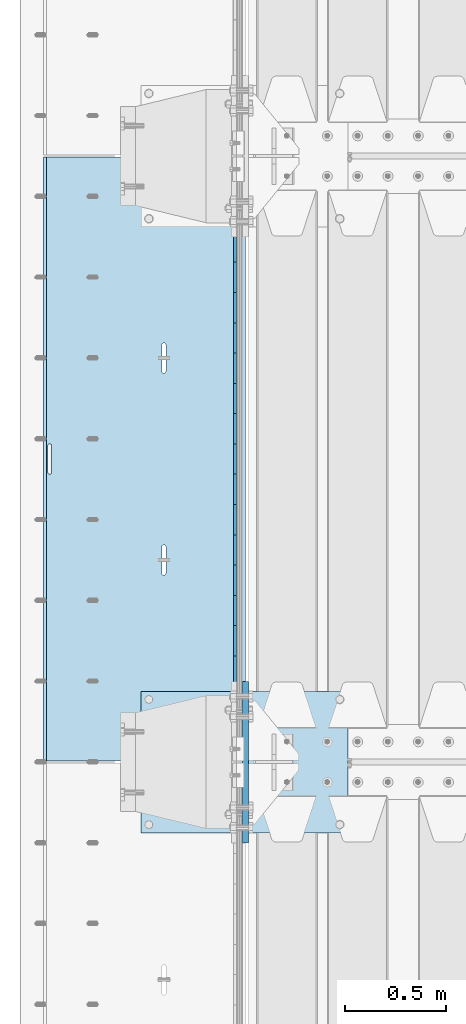
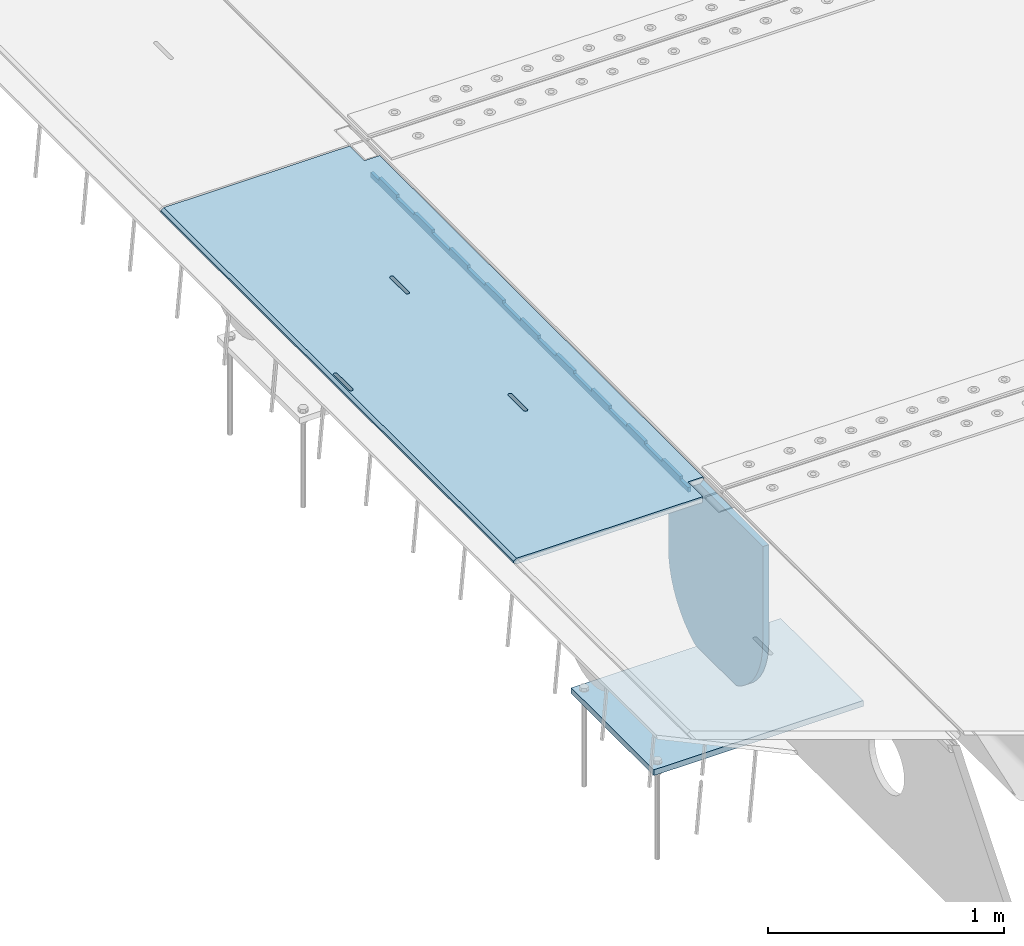
# One storey, part 196 of 257: 4 plates.
"""IFC2X3 building model written with IfcOpenShell, lengths in millimetres."""

from ifc_helpers import new_model, si_unit, frame, origin_with_axes, place, context, subcontext, project, spatial, faceted_brep, material, type_object, element, save


model = new_model("IFC2X3")

# Units and contexts
model_context = context("Model", 3, precision=1e-05, world=origin_with_axes())
body_context = subcontext(model_context, "Body", "Model", "MODEL_VIEW")
ifc_project = project(units=[si_unit("LENGTHUNIT", "METRE", prefix="MILLI"), si_unit("AREAUNIT", "SQUARE_METRE"), si_unit("VOLUMEUNIT", "CUBIC_METRE"), si_unit("MASSUNIT", "GRAM", prefix="KILO"), si_unit("TIMEUNIT", "SECOND"), si_unit("PLANEANGLEUNIT", "RADIAN"), si_unit("SOLIDANGLEUNIT", "STERADIAN"), si_unit("THERMODYNAMICTEMPERATUREUNIT", "DEGREE_CELSIUS"), si_unit("LUMINOUSINTENSITYUNIT", "LUMEN")], contexts=[model_context])

# Site, building, storey
site_placement = place(None, origin_with_axes())
site = spatial("IfcSite", under=ifc_project, at=site_placement, CompositionType="ELEMENT")
building_placement = place(site_placement, origin_with_axes())
building = spatial("IfcBuilding", under=site, at=building_placement, Name="Standard", CompositionType="ELEMENT")
storey_placement = place(building_placement, origin_with_axes())
storey = spatial("IfcBuildingStorey", under=building, at=storey_placement, Name="Undefined", CompositionType="ELEMENT", Elevation=0.0)

# Plates
ifc_material = material(Name="STEEL/S355N")
plate_type_1 = type_object("IfcPlateType", PredefinedType="NOTDEFINED")
plate_1_placement = place(storey_placement, frame((42392.5, 5845.00009945642, -36.018454190458), z_axis=(0.0, -0.999999999987744, -4.95099999993769e-06), x_axis=(0.0, 4.9510000093107e-06, -0.999999999987744)))
element("IfcPlate", 1, at=plate_1_placement, inside=storey, type_object=plate_type_1, material=ifc_material, context=body_context, shape_type="Brep", body=[
    faceted_brep([(7.105427357601e-15, -7.5, 0.0), (-1.24849464100407e-10, -7.5, 70.0), (-1.24849464100407e-10, 7.5, 70.0), (7.105427357601e-15, 7.5, 0.0), (-14.9899997711175, -7.5, 70.0), (-14.9899997711175, 7.5, 70.0), (-14.9899997711161, -7.5, 220.0), (-14.9899997711161, 7.5, 220.0), (-3.90826926377486e-10, -7.5, 220.0), (-3.90826926377486e-10, 7.5, 220.0), (-6.56825704936637e-10, -7.5, 370.0), (-6.56825704936637e-10, 7.5, 370.0), (-14.9899997711147, -7.5, 370.0), (-14.9899997711147, 7.5, 370.0), (-14.9899997711133, -7.5, 520.0), (-14.9899997711133, 7.5, 520.0), (-9.24622156617261e-10, -7.5, 520.0), (-9.24622156617261e-10, 7.5, 520.0), (-1.1906067243217e-09, -7.5, 669.999999999999), (-1.1906067243217e-09, 7.5, 669.999999999999), (-14.9899997711119, -7.5, 669.999999999999), (-14.9899997711119, 7.5, 669.999999999999), (-14.9899997711105, -7.5, 820.0), (-14.9899997711105, 7.5, 820.0), (-1.45477230262259e-09, -7.5, 820.0), (-1.45477230262259e-09, 7.5, 820.0), (-1.72258296515793e-09, -7.5, 970.0), (-1.72258296515793e-09, 7.5, 970.0), (-14.9899997711091, -7.5, 970.000000000001), (-14.9899997711091, 7.5, 970.000000000001), (-14.9899997711077, -7.5, 1120.0), (-14.9899997711077, 7.5, 1120.0), (-1.988560427435e-09, -7.5, 1120.0), (-1.988560427435e-09, 7.5, 1120.0), (-2.2545521005668e-09, -7.5, 1270.0), (-2.2545521005668e-09, 7.5, 1270.0), (-14.9899997711063, -7.5, 1270.0), (-14.9899997711063, 7.5, 1270.0), (-14.9899997711048, -7.5, 1420.0), (-14.9899997711048, 7.5, 1420.0), (-2.52235565767478e-09, -7.5, 1420.0), (-2.52235565767478e-09, 7.5, 1420.0), (-2.78834733080657e-09, -7.5, 1570.0), (-2.78834733080657e-09, 7.5, 1570.0), (-14.9899997711034, -7.5, 1570.0), (-14.9899997711034, 7.5, 1570.0), (-14.989999771102, -7.5, 1720.0), (-14.989999771102, 7.5, 1720.0), (-3.05432479308365e-09, -7.5, 1720.0), (-3.05432479308365e-09, 7.5, 1720.0), (-3.32212835019163e-09, -7.5, 1870.0), (-3.32212835019163e-09, 7.5, 1870.0), (-14.9899997711006, -7.5, 1870.0), (-14.9899997711006, 7.5, 1870.0), (-14.9899997710992, -7.5, 2020.0), (-14.9899997710992, 7.5, 2020.0), (-3.58812002332343e-09, -7.5, 2020.0), (-3.58812002332343e-09, 7.5, 2020.0), (-3.85410459102786e-09, -7.5, 2170.0), (-3.85410459102786e-09, 7.5, 2170.0), (-14.9899997710978, -7.5, 2170.0), (-14.9899997710978, 7.5, 2170.0), (-14.9899997710964, -7.5, 2320.0), (-14.9899997710964, 7.5, 2320.0), (-4.12190104270849e-09, -7.5, 2320.0), (-4.12190104270849e-09, 7.5, 2320.0), (-4.38789982126764e-09, -7.5, 2470.0), (-4.38789982126764e-09, 7.5, 2470.0), (-14.9999999999768, -7.5, 2470.0), (-14.9999999999768, 7.5, 2470.0), (-14.9899997710936, -7.5, 2620.0), (-14.9899997710936, 7.5, 2620.0), (-4.65387728354472e-09, -7.5, 2620.0), (-4.65387728354472e-09, 7.5, 2620.0), (-4.77872674764512e-09, -7.5, 2690.0), (-4.77872674764512e-09, 7.5, 2690.0), (25.0100002289071, -7.5, 2690.0), (25.0100002289071, 7.5, 2690.0), (25.0, -7.5, 0.0), (25.0, 7.5, 0.0)], [[[0, 1, 2, 3]], [[1, 4, 5, 2]], [[4, 6, 7, 5]], [[6, 8, 9, 7]], [[8, 10, 11, 9]], [[10, 12, 13, 11]], [[12, 14, 15, 13]], [[14, 16, 17, 15]], [[16, 18, 19, 17]], [[18, 20, 21, 19]], [[20, 22, 23, 21]], [[22, 24, 25, 23]], [[24, 26, 27, 25]], [[26, 28, 29, 27]], [[28, 30, 31, 29]], [[30, 32, 33, 31]], [[32, 34, 35, 33]], [[34, 36, 37, 35]], [[36, 38, 39, 37]], [[38, 40, 41, 39]], [[40, 42, 43, 41]], [[42, 44, 45, 43]], [[44, 46, 47, 45]], [[46, 48, 49, 47]], [[48, 50, 51, 49]], [[50, 52, 53, 51]], [[52, 54, 55, 53]], [[54, 56, 57, 55]], [[56, 58, 59, 57]], [[58, 60, 61, 59]], [[60, 62, 63, 61]], [[62, 64, 65, 63]], [[64, 66, 67, 65]], [[66, 68, 69, 67]], [[68, 70, 71, 69]], [[70, 72, 73, 71]], [[72, 74, 75, 73]], [[74, 76, 77, 75]], [[76, 78, 79, 77]], [[78, 0, 3, 79]], [[5, 7, 9, 11, 13, 15, 17, 19, 21, 23, 25, 27, 29, 31, 33, 35, 37, 39, 41, 43, 45, 47, 49, 51, 53, 55, 57, 59, 61, 63, 65, 67, 69, 71, 73, 75, 77, 79, 3, 2]], [[78, 76, 74, 72, 70, 68, 66, 64, 62, 60, 58, 56, 54, 52, 50, 48, 46, 44, 42, 40, 38, 36, 34, 32, 30, 28, 26, 24, 22, 20, 18, 16, 14, 12, 10, 8, 6, 4, 1, 0]]]),
])
plate_type_2 = type_object("IfcPlateType", PredefinedType="NOTDEFINED")
plate_2_placement = place(storey_placement, frame((42444.9962456697, 5994.99992617284, -1.00003031100477), z_axis=(0.0, -0.999999999987744, -4.95099999993769e-06), x_axis=(-0.999999999879068, -1.00000022173607e-09, -1.55519999981193e-05)))
element("IfcPlate", 2, at=plate_2_placement, inside=storey, type_object=plate_type_2, material=ifc_material, context=body_context, shape_type="Brep", body=[
    faceted_brep([(-0.00011158953566337, -5.71507075430855e-05, 2865.00000504124), (15.0002388791545, 15.0, 2865.00008049103), (15.0000104223, 15.0, 125.000079348153), (-0.000225737428991124, 5.71560199540411e-05, 125.000003632548), (999.996459960938, 5.0, 1.81898940354586e-12), (984.996459960938, 15.0, 1.81898940354586e-12), (984.996459730712, 15.0, 2990.0), (999.996459730719, 5.0, 2990.0), (999.996459730719, -5.0, 2990.0), (984.996459730522, -15.0, 2990.0), (984.996459961367, -15.0, 1.81898940354586e-12), (999.996459960938, -4.99999999999848, 1.81898940354586e-12), (959.99952227655, -15.0000000031848, 1560.00000000851), (959.99952227655, 15.0, 1560.00000000851), (960.488957113354, 15.0, 1563.09016995226), (960.488957113354, -15.0000000031888, 1563.09016995226), (961.909352332339, 15.0, 1565.87785253144), (961.909352332339, -15.0000000032008, 1565.87785253143), (964.121669752996, 15.0, 1568.09016995226), (964.121669752996, -15.0000000032196, 1568.09016995226), (966.909352332055, 15.0, 1569.51056517146), (966.909352332063, -15.0000000032433, 1569.51056517146), (969.999522275757, 15.0, 1570.00000000851), (969.999522275757, -15.0000000032698, 1570.00000000851), (973.089692219546, 15.0, 1569.51056517146), (973.089692219553, -15.0000000032963, 1569.51056517146), (975.877374798845, 15.0, 1568.09016995226), (975.877374798838, -15.0000000033202, 1568.09016995226), (978.08969221983, 15.0, 1565.87785253143), (978.089692219837, -15.0000000033393, 1565.87785253143), (979.510087439245, 15.0, 1563.09016995225), (979.510087439245, -15.0000000033517, 1563.09016995225), (979.999522276536, 15.0, 1560.0000000085), (979.999522276536, -15.0000000033561, 1560.0000000085), (979.99952228638, 15.0, 1430.0000000085), (979.999522286387, -15.0000000033654, 1430.0000000085), (979.510087449569, 15.0, 1426.90983006475), (979.510087449569, -15.0000000033615, 1426.90983006475), (978.089692230591, 15.0, 1424.12214748558), (978.089692230584, -15.0000000033495, 1424.12214748558), (975.877374809934, 15.0, 1421.90983006476), (975.877374809934, -15.0000000033307, 1421.90983006476), (973.089692230868, 15.0, 1420.48943484556), (973.089692230868, -15.000000003307, 1420.48943484556), (969.999522287319, 15.0, 1420.00000000851), (969.999522287319, -15.0000000032805, 1420.00000000851), (966.909352343529, 15.0, 1420.48943484556), (966.909352343537, -15.000000003254, 1420.48943484556), (964.121669764252, 15.0, 1421.90983006476), (964.121669764252, -15.00000000323, 1421.90983006476), (961.90935234326, 15.0, 1424.12214748559), (961.90935234326, -15.0000000032109, 1424.12214748559), (960.488957123831, 15.0, 1426.90983006476), (960.488957123831, -15.0000000031986, 1426.90983006476), (959.999522286547, 15.0, 1430.00000000851), (959.999522286547, -15.0000000031942, 1430.00000000851), (-0.000461898962385021, -14.9999999925605, 124.99992819726), (-0.000462055562820751, -14.9999999889596, 2864.99992960654), (75.0002624102563, 15.0, 125.000080471727), (74.999789880254, -15.0, 124.999929601727), (74.9997820615899, -15.0, 4.54747350886464e-13), (75.0002485915829, 15.0, 0.0), (75.0005015106071, 15.0, 2990.0), (75.0000289806048, -15.0, 2990.0), (75.0004911355936, 15.0, 2865.00008054905), (75.0000186055913, -14.999999997918, 2864.99992967905), (395.488957121597, -15.0, 1926.90983006544), (395.488957121597, 15.0, 1926.90983006544), (394.999522284306, 15.0, 1930.00000000919), (394.999522284306, -15.0, 1930.00000000919), (396.909352341019, -15.0, 1924.12214748626), (396.909352341019, 15.0, 1924.12214748626), (399.121669762011, -15.0, 1921.90983006544), (399.121669762018, 15.0, 1921.90983006544), (401.909352341303, -15.0, 1920.48943484623), (401.909352341296, 15.0, 1920.48943484623), (404.999522285085, -15.0, 1920.00000000919), (404.999522285085, 15.0, 1920.00000000919), (408.089692228663, -15.0, 1920.48943484623), (408.089692228663, 15.0, 1920.48943484623), (410.877374807715, -15.0, 1921.90983006543), (410.877374807715, 15.0, 1921.90983006543), (413.089692228379, -15.0, 1924.12214748626), (413.089692228379, 15.0, 1924.12214748626), (414.510087447357, -15.0, 1926.90983006543), (414.510087447357, 15.0, 1926.90983006543), (414.999522284175, -15.0, 1930.00000000918), (414.999522284175, 15.0, 1930.00000000918), (414.999522274302, -15.0, 2060.00000000918), (414.999522274302, 15.0, 2060.00000000918), (414.510087437011, -15.0, 2063.09016995293), (414.510087437011, 15.0, 2063.09016995293), (413.089692217596, -15.0, 2065.87785253211), (413.089692217589, 15.0, 2065.87785253211), (410.877374796597, -15.0, 2068.09016995293), (410.877374796597, 15.0, 2068.09016995293), (408.08969221732, -15.0, 2069.51056517214), (408.08969221732, 15.0, 2069.51056517214), (404.999522273523, -15.0, 2070.00000000919), (404.999522273523, 15.0, 2070.00000000919), (401.909352329829, -15.0, 2069.51056517214), (401.909352329822, 15.0, 2069.51056517214), (399.121669750755, -15.0, 2068.09016995293), (399.121669750763, 15.0, 2068.09016995294), (396.909352330098, -15.0, 2065.87785253211), (396.909352330105, 15.0, 2065.87785253211), (395.48895711112, -15.0, 2063.09016995294), (395.48895711112, 15.0, 2063.09016995294), (394.999522274309, -15.0, 2060.00000000919), (394.999522274309, 15.0, 2060.00000000919), (395.488957188121, -15.0, 1063.09016995158), (396.909352407114, -15.0, 1065.87785253076), (399.121669827771, -15.0, 1068.09016995158), (401.909352406838, -15.0, 1069.51056517079), (404.999522350532, -15.0, 1070.00000000783), (408.089692294328, -15.0, 1069.51056517079), (410.877374873613, -15.0, 1068.09016995158), (413.089692294612, -15.0, 1065.87785253075), (414.510087514012, -15.0, 1063.09016995158), (414.999522351303, -15.0, 1060.00000000783), (414.999522361184, -15.0, 930.000000007827), (414.510087524366, -15.0, 926.90983006408), (413.089692305388, -15.0, 924.122147484907), (410.877374884731, -15.0, 921.909830064084), (408.089692305664, -15.0, 920.489434844884), (404.999522362086, -15.0, 920.000000007836), (401.909352418312, -15.0, 920.489434844885), (399.121669839027, -15.0, 921.909830064088), (396.909352418028, -15.0, 924.122147484913), (395.488957198606, -15.0, 926.909830064087), (394.999522361322, -15.0, 930.000000007837), (394.999522351311, -15.0, 1060.00000000784), (396.909352418028, 15.0, 924.122147484912), (395.488957198606, 15.0, 926.909830064088), (399.121669839027, 15.0, 921.909830064087), (401.909352418304, 15.0, 920.489434844885), (404.999522362086, 15.0, 920.000000007837), (408.089692305664, 15.0, 920.489434844885), (410.877374884731, 15.0, 921.909830064085), (413.089692305388, 15.0, 924.122147484907), (414.510087524366, 15.0, 926.90983006408), (414.999522361184, 15.0, 930.000000007827), (414.999522351303, 15.0, 1060.00000000783), (414.51008751402, 15.0, 1063.09016995158), (413.089692294605, 15.0, 1065.87785253076), (410.877374873613, 15.0, 1068.09016995158), (408.089692294321, 15.0, 1069.51056517079), (404.999522350539, 15.0, 1070.00000000784), (401.909352406838, 15.0, 1069.51056517079), (399.121669827771, 15.0, 1068.09016995158), (396.909352407114, 15.0, 1065.87785253076), (395.488957188121, 15.0, 1063.09016995158), (394.999522351311, 15.0, 1060.00000000784), (394.999522361322, 15.0, 930.000000007837)], [[[0, 1, 2, 3]], [[4, 5, 6, 7]], [[8, 9, 10, 11]], [[12, 13, 14, 15]], [[15, 14, 16, 17]], [[17, 16, 18, 19]], [[19, 18, 20, 21]], [[21, 20, 22, 23]], [[23, 22, 24, 25]], [[25, 24, 26, 27]], [[27, 26, 28, 29]], [[29, 28, 30, 31]], [[31, 30, 32, 33]], [[33, 32, 34, 35]], [[35, 34, 36, 37]], [[37, 36, 38, 39]], [[39, 38, 40, 41]], [[41, 40, 42, 43]], [[43, 42, 44, 45]], [[45, 44, 46, 47]], [[47, 46, 48, 49]], [[49, 48, 50, 51]], [[51, 50, 52, 53]], [[53, 52, 54, 55]], [[55, 54, 13, 12]], [[56, 57, 0, 3]], [[58, 59, 56, 3, 2]], [[60, 59, 58, 61]], [[11, 10, 60, 61, 5, 4]], [[8, 11, 4, 7]], [[62, 63, 9, 8, 7, 6]], [[63, 62, 64, 65]], [[57, 65, 64, 1, 0]], [[66, 67, 68, 69]], [[70, 71, 67, 66]], [[72, 73, 71, 70]], [[74, 75, 73, 72]], [[76, 77, 75, 74]], [[78, 79, 77, 76]], [[80, 81, 79, 78]], [[82, 83, 81, 80]], [[84, 85, 83, 82]], [[86, 87, 85, 84]], [[88, 89, 87, 86]], [[90, 91, 89, 88]], [[92, 93, 91, 90]], [[94, 95, 93, 92]], [[96, 97, 95, 94]], [[98, 99, 97, 96]], [[100, 101, 99, 98]], [[102, 103, 101, 100]], [[104, 105, 103, 102]], [[106, 107, 105, 104]], [[108, 109, 107, 106]], [[69, 68, 109, 108]], [[63, 65, 57, 56, 59, 60, 10, 9], [15, 17, 19, 21, 23, 25, 27, 29, 31, 33, 35, 37, 39, 41, 43, 45, 47, 49, 51, 53, 55, 12], [110, 111, 112, 113, 114, 115, 116, 117, 118, 119, 120, 121, 122, 123, 124, 125, 126, 127, 128, 129, 130, 131], [106, 104, 102, 100, 98, 96, 94, 92, 90, 88, 86, 84, 82, 80, 78, 76, 74, 72, 70, 66, 69, 108]], [[128, 132, 133, 129]], [[127, 134, 132, 128]], [[126, 135, 134, 127]], [[125, 136, 135, 126]], [[124, 137, 136, 125]], [[123, 138, 137, 124]], [[122, 139, 138, 123]], [[121, 140, 139, 122]], [[120, 141, 140, 121]], [[119, 142, 141, 120]], [[118, 143, 142, 119]], [[117, 144, 143, 118]], [[116, 145, 144, 117]], [[115, 146, 145, 116]], [[114, 147, 146, 115]], [[113, 148, 147, 114]], [[112, 149, 148, 113]], [[111, 150, 149, 112]], [[110, 151, 150, 111]], [[131, 152, 151, 110]], [[130, 153, 152, 131]], [[129, 133, 153, 130]], [[64, 62, 6, 5, 61, 58, 2, 1], [50, 48, 46, 44, 42, 40, 38, 36, 34, 32, 30, 28, 26, 24, 22, 20, 18, 16, 14, 13, 54, 52], [132, 134, 135, 136, 137, 138, 139, 140, 141, 142, 143, 144, 145, 146, 147, 148, 149, 150, 151, 152, 153, 133], [71, 73, 75, 77, 79, 81, 83, 85, 87, 89, 91, 93, 95, 97, 99, 101, 103, 105, 107, 109, 68, 67]]]),
])
plate_type_3 = type_object("IfcPlateType", PredefinedType="NOTDEFINED")
plate_3_placement = place(storey_placement, frame((42445.0, 2600.0, -20.0), z_axis=(0.0, 1.0, 0.0), x_axis=(0.0, 0.0, -1.0)))
element("IfcPlate", 3, at=plate_3_placement, inside=storey, type_object=plate_type_3, material=ifc_material, context=body_context, shape_type="Brep", body=[
    faceted_brep([(855.0, -15.0, 572.96311467154), (855.0, 15.0, 572.96311467154), (849.182410261294, 15.0, 585.889268817531), (849.182410261294, -15.0, 585.889268817531), (824.193546357474, 15.0, 627.225898692485), (824.193546357474, -15.0, 627.225898692485), (794.404299268454, 15.0, 665.249063296341), (794.404299268454, -15.0, 665.249063296341), (760.249063296334, 15.0, 699.404299268464), (760.249063296334, -15.0, 699.404299268464), (722.22589869248, 15.0, 729.193546357486), (722.22589869248, -15.0, 729.193546357486), (680.889268817528, 15.0, 754.182410261309), (680.889268817528, -15.0, 754.182410261309), (636.841954817037, 15.0, 774.006497074193), (636.841954817037, -15.0, 774.006497074193), (590.726265715048, 15.0, 788.37672697045), (590.726265715048, -15.0, 788.37672697045), (543.214672102156, 15.0, 797.083549639254), (543.214672102156, -15.0, 797.083549639254), (495.0, -15.0, 800.000000000029), (495.0, 15.0, 800.0), (494.999999999412, -15.0, 0.0), (494.999999999412, 15.0, 0.0), (543.214672102129, 15.0, 2.91645036080718), (543.214672102129, -15.0, 2.91645036080718), (590.726265715023, 15.0, 11.6232730296088), (590.726265715023, -15.0, 11.6232730296088), (636.841954817014, 15.0, 25.9935029258631), (636.841954817014, -15.0, 25.9935029258631), (680.889268817507, 15.0, 45.8175897387455), (680.889268817507, -15.0, 45.8175897387455), (722.225898692462, 15.0, 70.8064536425663), (722.225898692462, -15.0, 70.8064536425663), (760.249063296318, 15.0, 100.595700731588), (760.249063296318, -15.0, 100.595700731588), (794.404299268441, 15.0, 134.750936703711), (794.404299268441, -15.0, 134.750936703711), (824.193546357463, 15.0, 172.774101307567), (824.193546357463, -15.0, 172.774101307567), (849.182410261284, 15.0, 214.110731182522), (849.182410261284, -15.0, 214.110731182522), (855.0, -15.0, 227.036885328535), (855.0, 15.0, 227.036885328535), (0.0, -15.0, 0.0), (0.0, 15.0, 0.0), (0.0, 15.0, 800.0), (0.0, -15.0, 800.0)], [[[0, 1, 2, 3]], [[3, 2, 4, 5]], [[5, 4, 6, 7]], [[7, 6, 8, 9]], [[9, 8, 10, 11]], [[11, 10, 12, 13]], [[13, 12, 14, 15]], [[15, 14, 16, 17]], [[17, 16, 18, 19]], [[20, 19, 18, 21]], [[22, 23, 24, 25]], [[25, 24, 26, 27]], [[27, 26, 28, 29]], [[29, 28, 30, 31]], [[31, 30, 32, 33]], [[33, 32, 34, 35]], [[35, 34, 36, 37]], [[37, 36, 38, 39]], [[39, 38, 40, 41]], [[42, 41, 40, 43]], [[42, 43, 1, 0]], [[44, 45, 23, 22]], [[16, 14, 12, 10, 8, 6, 4, 2, 1, 43, 40, 38, 36, 34, 32, 30, 28, 26, 24, 23, 45, 46, 21, 18]], [[44, 47, 46, 45]], [[46, 47, 20, 21]], [[47, 44, 22, 25, 27, 29, 31, 33, 35, 37, 39, 41, 42, 0, 3, 5, 7, 9, 11, 13, 15, 17, 19, 20]]]),
])
plate_type_4 = type_object("IfcPlateType", PredefinedType="NOTDEFINED")
plate_4_placement = place(storey_placement, frame((41926.0, 3350.0, -1043.0), z_axis=(1.0, 0.0, 0.0), x_axis=(0.0, -1.0, 0.0)))
element("IfcPlate", 4, at=plate_4_placement, inside=storey, type_object=plate_type_4, material=ifc_material, context=body_context, shape_type="Brep", body=[
    faceted_brep([(0.0, -15.0, 0.0), (3.03448287013453e-05, -15.0, 1025.0), (3.03448287013453e-05, 15.0, 1025.0), (0.0, 15.0, 0.0), (700.0, -15.0, 1025.0), (700.0, 15.0, 1025.0), (700.0, -15.0, -7.27595761418343e-12), (700.0, 15.0, -7.27595761418343e-12)], [[[0, 1, 2, 3]], [[1, 4, 5, 2]], [[4, 6, 7, 5]], [[6, 0, 3, 7]], [[5, 7, 3, 2]], [[6, 4, 1, 0]]]),
])

save(model, "model.ifc")
